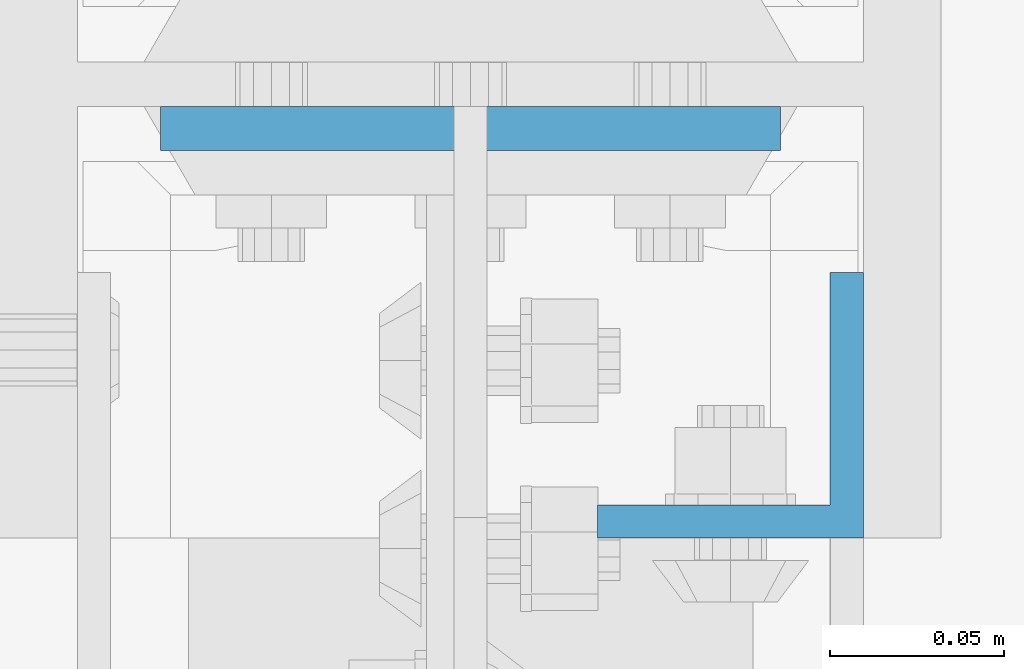
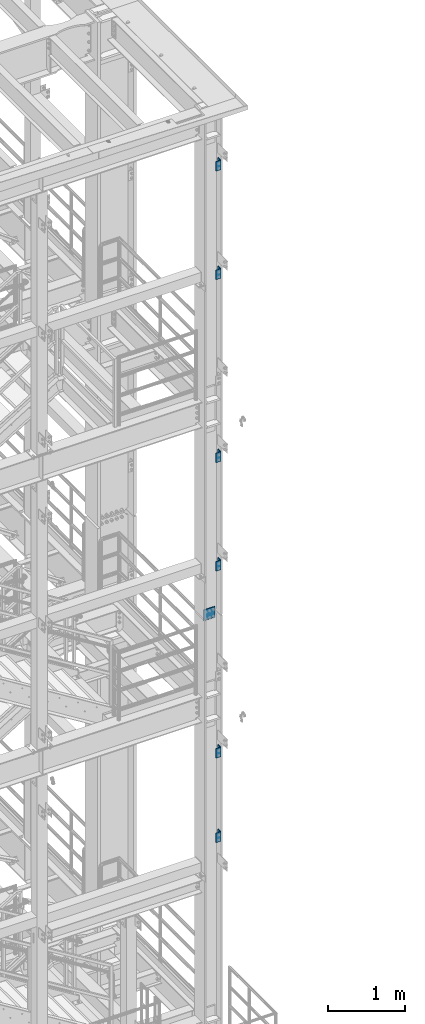
# One storey, part 1215 of 1876: 7 beams, 2 elements without a shape of their own.
"""IFC2X3 building model written with IfcOpenShell, lengths in millimetres."""

from ifc_helpers import new_model, si_unit, frame, origin_with_axes, place, context, subcontext, project, spatial, faceted_brep, material, type_object, element, aggregate, save


model = new_model("IFC2X3")

# Units and contexts
model_context = context("Model", 3, precision=1e-05, world=origin_with_axes())
body_context = subcontext(model_context, "Body", "Model", "MODEL_VIEW")
ifc_project = project(units=[si_unit("LENGTHUNIT", "METRE", prefix="MILLI"), si_unit("AREAUNIT", "SQUARE_METRE"), si_unit("VOLUMEUNIT", "CUBIC_METRE"), si_unit("MASSUNIT", "GRAM", prefix="KILO"), si_unit("TIMEUNIT", "SECOND"), si_unit("PLANEANGLEUNIT", "RADIAN"), si_unit("SOLIDANGLEUNIT", "STERADIAN"), si_unit("THERMODYNAMICTEMPERATUREUNIT", "DEGREE_CELSIUS"), si_unit("LUMINOUSINTENSITYUNIT", "LUMEN")], contexts=[model_context])

# Site, building, storey
site_placement = place(None, origin_with_axes())
site = spatial("IfcSite", under=ifc_project, at=site_placement, CompositionType="ELEMENT")
building_placement = place(site_placement, origin_with_axes())
building = spatial("IfcBuilding", under=site, at=building_placement, Name="Undefined", CompositionType="ELEMENT")
storey_placement = place(building_placement, origin_with_axes())
storey = spatial("IfcBuildingStorey", under=building, at=storey_placement, Name="Undefined", CompositionType="ELEMENT", Elevation=0.0)

# Assembly, beams
assembly_1_placement = place(storey_placement, origin_with_axes())
assembly_1 = element("IfcElementAssembly", 1, at=assembly_1_placement, inside=storey, Name="COLUMN", AssemblyPlace="NOTDEFINED", PredefinedType="RIGID_FRAME")
ifc_material_1 = material(Name="STEEL/A36")
beam_type_1 = type_object("IfcBeamType", Name="L3X3X3/8", PredefinedType="NOTDEFINED")
beam_1_placement = place(assembly_1_placement, frame((7694.53692732059, -7204.075, 21755.1), z_axis=(-1.0, 0.0, 0.0), x_axis=(0.0, 0.0, -1.0)))
beam_1 = element("IfcBeam", 2, at=beam_1_placement, type_object=beam_type_1, material=ifc_material_1, Name="ANGLE", ObjectType="L3X3X3/8", context=body_context, shape_type="Brep", body=[
    faceted_brep([(0.0, 38.1000000000004, -38.1), (0.0, 38.1000000000004, 38.1), (152.4, 38.1000000000004, 38.1), (152.4, 38.1000000000004, -38.1), (0.0, 28.5749999999998, 38.1), (152.4, 28.5749999999998, 38.1), (0.0, 28.5749999999998, -28.575), (152.4, 28.5749999999998, -28.575), (0.0, -38.1000000000004, -28.575), (152.4, -38.1000000000004, -28.575), (0.0, -38.1000000000004, -38.1), (152.4, -38.1000000000004, -38.1)], [[[0, 1, 2, 3]], [[1, 4, 5, 2]], [[4, 6, 7, 5]], [[6, 8, 9, 7]], [[8, 10, 11, 9]], [[10, 0, 3, 11]], [[5, 7, 9, 11, 3, 2]], [[10, 8, 6, 4, 1, 0]]]),
])
beam_2_placement = place(assembly_1_placement, frame((7694.53692732059, -7204.075, 20034.25), z_axis=(-1.0, 0.0, 0.0), x_axis=(0.0, 0.0, -1.0)))
beam_2 = element("IfcBeam", 3, at=beam_2_placement, type_object=beam_type_1, material=ifc_material_1, Name="ANGLE", ObjectType="L3X3X3/8", context=body_context, shape_type="Brep", body=[
    faceted_brep([(0.0, 38.1000000000004, -38.1), (0.0, 38.1000000000004, 38.1), (152.4, 38.1000000000004, 38.1), (152.4, 38.1000000000004, -38.1), (0.0, 28.5749999999998, 38.1), (152.4, 28.5749999999998, 38.1), (0.0, 28.5749999999998, -28.575), (152.4, 28.5749999999998, -28.575), (0.0, -38.1000000000004, -28.575), (152.4, -38.1000000000004, -28.575), (0.0, -38.1000000000004, -38.1), (152.4, -38.1000000000004, -38.1)], [[[0, 1, 2, 3]], [[1, 4, 5, 2]], [[4, 6, 7, 5]], [[6, 8, 9, 7]], [[8, 10, 11, 9]], [[10, 0, 3, 11]], [[5, 7, 9, 11, 3, 2]], [[10, 8, 6, 4, 1, 0]]]),
])
beam_3_placement = place(assembly_1_placement, frame((7694.53692732059, -7204.075, 17132.3), z_axis=(-1.0, 0.0, 0.0), x_axis=(0.0, 0.0, -1.0)))
beam_3 = element("IfcBeam", 4, at=beam_3_placement, type_object=beam_type_1, material=ifc_material_1, Name="ANGLE", ObjectType="L3X3X3/8", context=body_context, shape_type="Brep", body=[
    faceted_brep([(0.0, 38.1000000000004, -38.1), (0.0, 38.1000000000004, 38.1), (152.4, 38.1000000000004, 38.1), (152.4, 38.1000000000004, -38.1), (0.0, 28.5749999999998, 38.1), (152.4, 28.5749999999998, 38.1), (0.0, 28.5749999999998, -28.575), (152.4, 28.5749999999998, -28.575), (0.0, -38.1000000000004, -28.575), (152.4, -38.1000000000004, -28.575), (0.0, -38.1000000000004, -38.1), (152.4, -38.1000000000004, -38.1)], [[[0, 1, 2, 3]], [[1, 4, 5, 2]], [[4, 6, 7, 5]], [[6, 8, 9, 7]], [[8, 10, 11, 9]], [[10, 0, 3, 11]], [[5, 7, 9, 11, 3, 2]], [[10, 8, 6, 4, 1, 0]]]),
])
beam_4_placement = place(assembly_1_placement, frame((7694.53692732059, -7204.075, 15411.45), z_axis=(-1.0, 0.0, 0.0), x_axis=(0.0, 0.0, -1.0)))
beam_4 = element("IfcBeam", 5, at=beam_4_placement, type_object=beam_type_1, material=ifc_material_1, Name="ANGLE", ObjectType="L3X3X3/8", context=body_context, shape_type="Brep", body=[
    faceted_brep([(0.0, 38.1000000000004, -38.1), (0.0, 38.1000000000004, 38.1), (152.4, 38.1000000000004, 38.1), (152.4, 38.1000000000004, -38.1), (0.0, 28.5749999999998, 38.1), (152.4, 28.5749999999998, 38.1), (0.0, 28.5749999999998, -28.575), (152.4, 28.5749999999998, -28.575), (0.0, -38.1000000000004, -28.575), (152.4, -38.1000000000004, -28.575), (0.0, -38.1000000000004, -38.1), (152.4, -38.1000000000004, -38.1)], [[[0, 1, 2, 3]], [[1, 4, 5, 2]], [[4, 6, 7, 5]], [[6, 8, 9, 7]], [[8, 10, 11, 9]], [[10, 0, 3, 11]], [[5, 7, 9, 11, 3, 2]], [[10, 8, 6, 4, 1, 0]]]),
])
aggregate(assembly_1, [beam_1, beam_2, beam_3, beam_4])

assembly_2_placement = place(storey_placement, origin_with_axes())
assembly_2 = element("IfcElementAssembly", 6, at=assembly_2_placement, inside=storey, Name="COLUMN", AssemblyPlace="NOTDEFINED", PredefinedType="RIGID_FRAME")
beam_5_placement = place(assembly_2_placement, frame((7694.53692732059, -7204.075, 12446.0), z_axis=(-1.0, 0.0, 0.0), x_axis=(0.0, 0.0, -1.0)))
beam_5 = element("IfcBeam", 7, at=beam_5_placement, type_object=beam_type_1, material=ifc_material_1, Name="ANGLE", ObjectType="L3X3X3/8", context=body_context, shape_type="Brep", body=[
    faceted_brep([(0.0, 38.1000000000004, -38.1), (0.0, 38.1000000000004, 38.1), (152.4, 38.1000000000004, 38.1), (152.4, 38.1000000000004, -38.1), (0.0, 28.5749999999998, 38.1), (152.4, 28.5749999999998, 38.1), (0.0, 28.5749999999998, -28.575), (152.4, 28.5749999999998, -28.575), (0.0, -38.1000000000004, -28.575), (152.4, -38.1000000000004, -28.575), (0.0, -38.1000000000004, -38.1), (152.4, -38.1000000000004, -38.1)], [[[0, 1, 2, 3]], [[1, 4, 5, 2]], [[4, 6, 7, 5]], [[6, 8, 9, 7]], [[8, 10, 11, 9]], [[10, 0, 3, 11]], [[5, 7, 9, 11, 3, 2]], [[10, 8, 6, 4, 1, 0]]]),
])
beam_6_placement = place(assembly_2_placement, frame((7694.53692732059, -7204.075, 11106.15), z_axis=(-1.0, 0.0, 0.0), x_axis=(0.0, 0.0, -1.0)))
beam_6 = element("IfcBeam", 8, at=beam_6_placement, type_object=beam_type_1, material=ifc_material_1, Name="ANGLE", ObjectType="L3X3X3/8", context=body_context, shape_type="Brep", body=[
    faceted_brep([(0.0, 38.1000000000004, -38.1), (0.0, 38.1000000000004, 38.1), (152.4, 38.1000000000004, 38.1), (152.4, 38.1000000000004, -38.1), (0.0, 28.5749999999998, 38.1), (152.4, 28.5749999999998, 38.1), (0.0, 28.5749999999998, -28.575), (152.4, 28.5749999999998, -28.575), (0.0, -38.1000000000004, -28.575), (152.4, -38.1000000000004, -28.575), (0.0, -38.1000000000004, -38.1), (152.4, -38.1000000000004, -38.1)], [[[0, 1, 2, 3]], [[1, 4, 5, 2]], [[4, 6, 7, 5]], [[6, 8, 9, 7]], [[8, 10, 11, 9]], [[10, 0, 3, 11]], [[5, 7, 9, 11, 3, 2]], [[10, 8, 6, 4, 1, 0]]]),
])
ifc_material_2 = material(Name="STEEL/A572-50")
beam_type_2 = type_object("IfcBeamType", PredefinedType="NOTDEFINED")
beam_7_placement = place(assembly_2_placement, frame((7620.0, -7124.7, 14617.7), z_axis=(-1.0, 0.0, 0.0), x_axis=(0.0, 0.0, -1.0)))
beam_7 = element("IfcBeam", 9, at=beam_7_placement, type_object=beam_type_2, material=ifc_material_2, Name="PLATE", context=body_context, shape_type="Brep", body=[
    faceted_brep([(0.0, 6.35000000000036, -88.9), (0.0, 6.35000000000036, 88.9), (171.449999999999, 6.35000000000036, 88.9), (171.449999999999, 6.35000000000036, -88.9), (0.0, -6.35000000000036, 88.9), (171.449999999999, -6.35000000000036, 88.9), (0.0, -6.35000000000036, -88.9), (171.449999999999, -6.35000000000036, -88.9)], [[[0, 1, 2, 3]], [[1, 4, 5, 2]], [[4, 6, 7, 5]], [[6, 0, 3, 7]], [[5, 7, 3, 2]], [[6, 4, 1, 0]]]),
])
aggregate(assembly_2, [beam_5, beam_6, beam_7])

save(model, "model.ifc")
